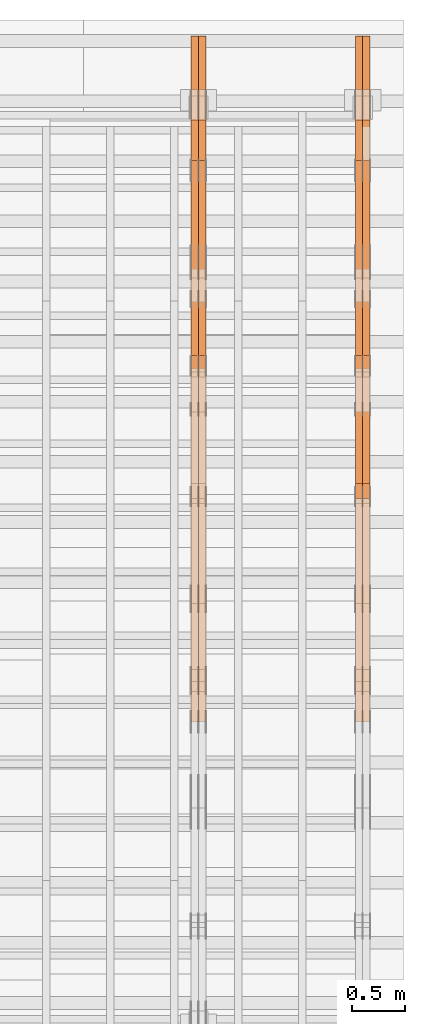
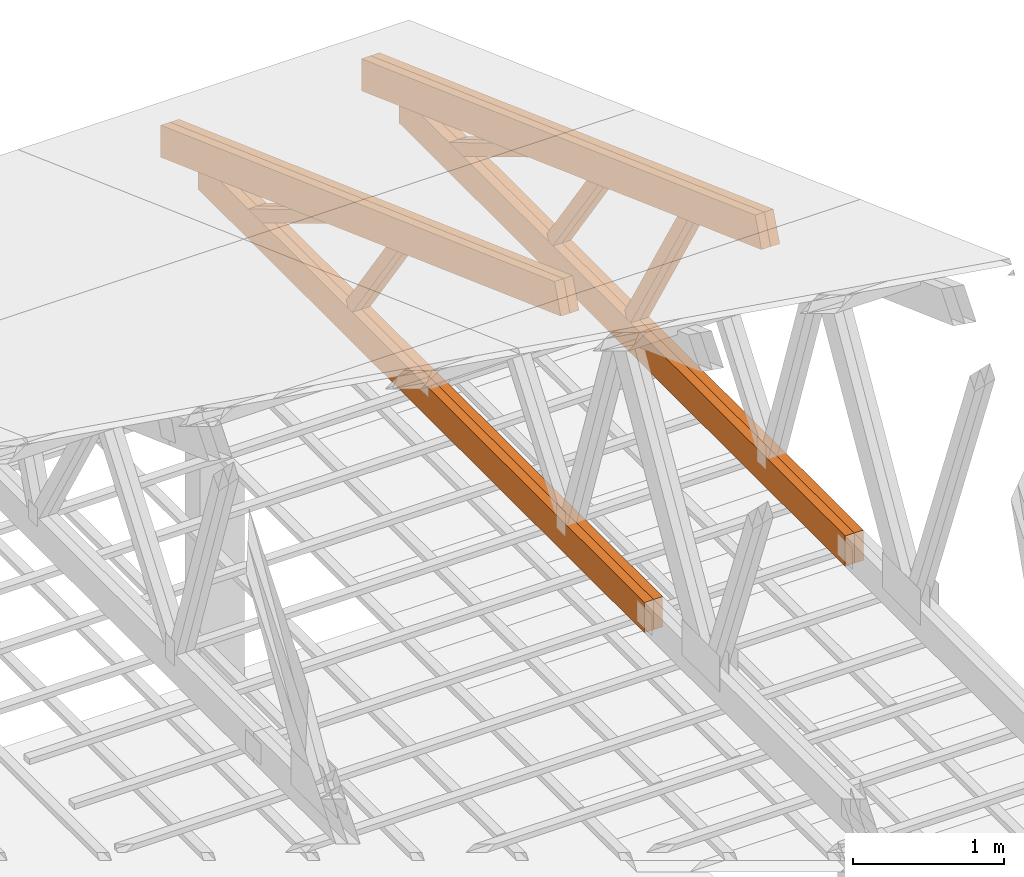
# One storey, part 66 of 189: 18 proxies.
"""IFC2X3 building model written with IfcOpenShell, lengths in millimetres."""

from ifc_helpers import new_model, entity, si_unit, converted_unit, derived_unit, direction, frame, origin, place, context, subcontext, project, spatial, polyline, outline, extrude, source, transform, mapped, material, type_object, type_shapes, element, save


model = new_model("IFC2X3")

# Units and contexts
model_context = context("Model", 3, precision=0.01, world=origin(), true_north=direction((6.12303176911189e-17, 1.0)))
body_context = subcontext(model_context, "Body", "Model", "MODEL_VIEW")
ifc_project = project(units=[si_unit("LENGTHUNIT", "METRE", prefix="MILLI"), si_unit("AREAUNIT", "SQUARE_METRE"), si_unit("VOLUMEUNIT", "CUBIC_METRE"), converted_unit("PLANEANGLEUNIT", "DEGREE", entity("IfcRatioMeasure", 0.0174532925199433), si_unit("PLANEANGLEUNIT", "RADIAN"), dimensions=[0, 0, 0, 0, 0, 0, 0]), si_unit("MASSUNIT", "GRAM", prefix="KILO"), derived_unit("MASSDENSITYUNIT", [(si_unit("MASSUNIT", "GRAM", prefix="KILO"), 1), (si_unit("LENGTHUNIT", "METRE"), -3)]), si_unit("TIMEUNIT", "SECOND"), si_unit("FREQUENCYUNIT", "HERTZ"), si_unit("THERMODYNAMICTEMPERATUREUNIT", "DEGREE_CELSIUS"), derived_unit("THERMALTRANSMITTANCEUNIT", [(si_unit("MASSUNIT", "GRAM", prefix="KILO"), 1), (si_unit("THERMODYNAMICTEMPERATUREUNIT", "KELVIN"), -1), (si_unit("TIMEUNIT", "SECOND"), -3)]), derived_unit("VOLUMETRICFLOWRATEUNIT", [(si_unit("LENGTHUNIT", "METRE"), 3), (si_unit("TIMEUNIT", "SECOND"), -1)]), si_unit("ELECTRICCURRENTUNIT", "AMPERE"), si_unit("ELECTRICVOLTAGEUNIT", "VOLT"), si_unit("POWERUNIT", "WATT"), si_unit("FORCEUNIT", "NEWTON"), si_unit("ILLUMINANCEUNIT", "LUX"), si_unit("LUMINOUSFLUXUNIT", "LUMEN"), si_unit("LUMINOUSINTENSITYUNIT", "CANDELA"), derived_unit("USERDEFINED", [(si_unit("MASSUNIT", "GRAM", prefix="KILO"), -1), (si_unit("LENGTHUNIT", "METRE"), -2), (si_unit("TIMEUNIT", "SECOND"), 3), (si_unit("LUMINOUSFLUXUNIT", "LUMEN"), 1)]), derived_unit("LINEARVELOCITYUNIT", [(si_unit("LENGTHUNIT", "METRE"), 1), (si_unit("TIMEUNIT", "SECOND"), -1)]), si_unit("PRESSUREUNIT", "PASCAL"), derived_unit("USERDEFINED", [(si_unit("LENGTHUNIT", "METRE"), -2), (si_unit("MASSUNIT", "GRAM", prefix="KILO"), 1), (si_unit("TIMEUNIT", "SECOND"), -2)])], contexts=[model_context])

# Site, building, storey
site_placement = place(None, origin())
site = spatial("IfcSite", under=ifc_project, at=site_placement, CompositionType="ELEMENT")
building_placement = place(site_placement, origin())
building = spatial("IfcBuilding", under=site, at=building_placement, CompositionType="ELEMENT")
storey_placement = place(building_placement, origin())
storey = spatial("IfcBuildingStorey", under=building, at=storey_placement, Name="Default", CompositionType="ELEMENT", Elevation=0.0)

# Proxies
ifc_material_1 = material(Name="IfcSurfaceStyle #271132")
building_element_proxy_type_1 = type_object("IfcBuildingElementProxyType", Name="T1-W11 271130", PredefinedType="NOTDEFINED", material=ifc_material_1)
shared_shape_1 = source(origin(), body_context, "Body", "SweptSolid", [
    extrude(outline(polyline([(-809.410890003667, -47.5000077306544), (561.624013869753, -47.5000077306544), (599.944137054867, -7.52294285037536e-05), (572.078784657538, 47.5000453453687), (-924.236045578491, 47.5000453453687), (-809.410890003667, -47.5000077306544)])), frame((599.944137054867, 47.5000453453687, 0.0), z_axis=(0.0, 0.0, 1.0), x_axis=(-1.0, 0.0, 0.0)), (0.0, 0.0, 1.0), 69.9999999999999),
])
type_shapes(building_element_proxy_type_1, [shared_shape_1])
proxy_1_placement = place(building_placement, frame((49840.0, 26434.7921369083, 220.965133687368), z_axis=(-1.0, 0.0, 0.0), x_axis=(0.0, -0.505995901100603, 0.862535882192381)))
element("IfcBuildingElementProxy", 1, at=proxy_1_placement, inside=storey, type_object=building_element_proxy_type_1, material=ifc_material_1, Name="T1-W11", context=body_context, shape_type="MappedRepresentation", body=[
    mapped(shared_shape_1, transform((0.0, 0.0, 0.0), scale=1.0)),
])
ifc_material_2 = material(Name="IfcSurfaceStyle #271066")
building_element_proxy_type_2 = type_object("IfcBuildingElementProxyType", Name="T1-W11 271064", PredefinedType="NOTDEFINED", material=ifc_material_2)
shared_shape_2 = source(origin(), body_context, "Body", "SweptSolid", [
    extrude(outline(polyline([(-809.410890003667, -47.5000077306544), (561.624013869753, -47.5000077306544), (599.944137054867, -7.52294285037536e-05), (572.078784657538, 47.5000453453687), (-924.236045578491, 47.5000453453687), (-809.410890003667, -47.5000077306544)])), frame((599.944137054867, 47.5000453453687, 0.0), z_axis=(0.0, 0.0, 1.0), x_axis=(-1.0, 0.0, 0.0)), (0.0, 0.0, 1.0), 69.9999999999999),
])
type_shapes(building_element_proxy_type_2, [shared_shape_2])
proxy_2_placement = place(building_placement, frame((49770.0, 26434.7921369083, 220.965133687368), z_axis=(-1.0, 0.0, 0.0), x_axis=(0.0, -0.505995901100603, 0.862535882192381)))
element("IfcBuildingElementProxy", 2, at=proxy_2_placement, inside=storey, type_object=building_element_proxy_type_2, material=ifc_material_2, Name="T1-W11", context=body_context, shape_type="MappedRepresentation", body=[
    mapped(shared_shape_2, transform((0.0, 0.0, 0.0), scale=1.0)),
])
ifc_material_3 = material(Name="IfcSurfaceStyle #270604")
building_element_proxy_type_3 = type_object("IfcBuildingElementProxyType", Name="T1-W13 270602", PredefinedType="NOTDEFINED", material=ifc_material_3)
shared_shape_3 = source(origin(), body_context, "Body", "SweptSolid", [
    extrude(outline(polyline([(-527.416466728212, -47.5000272833949), (387.658053197984, -47.5000272833949), (418.029495084182, -7.96824534414764e-06), (384.779443025059, 47.5000312675175), (-663.050524579013, 47.5000312675176), (-527.416466728212, -47.5000272833949)])), frame((418.029495084182, 47.5000671658844, 0.0), z_axis=(0.0, 0.0, 1.0), x_axis=(-1.0, 0.0, 0.0)), (0.0, 0.0, 1.0), 69.9999999999999),
])
type_shapes(building_element_proxy_type_3, [shared_shape_3])
proxy_3_placement = place(building_placement, frame((49840.0, 27471.0085508293, 217.760482033818), z_axis=(-1.0, 0.0, 0.0), x_axis=(0.0, -0.573462629043498, 0.819231721242848)))
element("IfcBuildingElementProxy", 3, at=proxy_3_placement, inside=storey, type_object=building_element_proxy_type_3, material=ifc_material_3, Name="T1-W13", context=body_context, shape_type="MappedRepresentation", body=[
    mapped(shared_shape_3, transform((0.0, 0.0, 0.0), scale=1.0)),
])
ifc_material_4 = material(Name="IfcSurfaceStyle #270538")
building_element_proxy_type_4 = type_object("IfcBuildingElementProxyType", Name="T1-W13 270536", PredefinedType="NOTDEFINED", material=ifc_material_4)
shared_shape_4 = source(origin(), body_context, "Body", "SweptSolid", [
    extrude(outline(polyline([(-527.416466728212, -47.5000272833949), (387.658053197984, -47.5000272833949), (418.029495084182, -7.96824534414764e-06), (384.779443025059, 47.5000312675175), (-663.050524579013, 47.5000312675176), (-527.416466728212, -47.5000272833949)])), frame((418.029495084182, 47.5000671658844, 0.0), z_axis=(0.0, 0.0, 1.0), x_axis=(-1.0, 0.0, 0.0)), (0.0, 0.0, 1.0), 69.9999999999999),
])
type_shapes(building_element_proxy_type_4, [shared_shape_4])
proxy_4_placement = place(building_placement, frame((49770.0, 27471.0085508293, 217.760482033818), z_axis=(-1.0, 0.0, 0.0), x_axis=(0.0, -0.573462629043498, 0.819231721242848)))
element("IfcBuildingElementProxy", 4, at=proxy_4_placement, inside=storey, type_object=building_element_proxy_type_4, material=ifc_material_4, Name="T1-W13", context=body_context, shape_type="MappedRepresentation", body=[
    mapped(shared_shape_4, transform((0.0, 0.0, 0.0), scale=1.0)),
])
ifc_material_5 = material(Name="IfcSurfaceStyle #270094")
building_element_proxy_type_5 = type_object("IfcBuildingElementProxyType", Name="T1-W12 270092", PredefinedType="NOTDEFINED", material=ifc_material_5)
shared_shape_5 = source(origin(), body_context, "Body", "SweptSolid", [
    extrude(outline(polyline([(-176.861423449428, -47.5000064161489), (503.856777435794, -47.5000064161489), (344.893496040196, 47.5000064161489), (-671.888850026563, 47.5000064161488), (-176.861423449428, -47.5000064161489)])), frame((503.856799890979, 47.5000428456028, 0.0), z_axis=(0.0, 0.0, 1.0), x_axis=(-1.0, 0.0, 0.0)), (0.0, 0.0, 1.0), 69.9999999999999),
])
type_shapes(building_element_proxy_type_5, [shared_shape_5])
proxy_5_placement = place(building_placement, frame((49840.0, 28785.6842742264, 163.452728724015), z_axis=(-1.0, 0.0, 0.0), x_axis=(0.0, -0.858392121304013, 0.51299411895576)))
element("IfcBuildingElementProxy", 5, at=proxy_5_placement, inside=storey, type_object=building_element_proxy_type_5, material=ifc_material_5, Name="T1-W12", context=body_context, shape_type="MappedRepresentation", body=[
    mapped(shared_shape_5, transform((0.0, 0.0, 0.0), scale=1.0)),
])
ifc_material_6 = material(Name="IfcSurfaceStyle #270037")
building_element_proxy_type_6 = type_object("IfcBuildingElementProxyType", Name="T1-W12 270035", PredefinedType="NOTDEFINED", material=ifc_material_6)
shared_shape_6 = source(origin(), body_context, "Body", "SweptSolid", [
    extrude(outline(polyline([(-176.861423449428, -47.5000064161489), (503.856777435794, -47.5000064161489), (344.893496040196, 47.5000064161489), (-671.888850026563, 47.5000064161488), (-176.861423449428, -47.5000064161489)])), frame((503.856799890979, 47.5000428456028, 0.0), z_axis=(0.0, 0.0, 1.0), x_axis=(-1.0, 0.0, 0.0)), (0.0, 0.0, 1.0), 69.9999999999999),
])
type_shapes(building_element_proxy_type_6, [shared_shape_6])
proxy_6_placement = place(building_placement, frame((49770.0, 28785.6842742264, 163.452728724015), z_axis=(-1.0, 0.0, 0.0), x_axis=(0.0, -0.858392121304013, 0.51299411895576)))
element("IfcBuildingElementProxy", 6, at=proxy_6_placement, inside=storey, type_object=building_element_proxy_type_6, material=ifc_material_6, Name="T1-W12", context=body_context, shape_type="MappedRepresentation", body=[
    mapped(shared_shape_6, transform((0.0, 0.0, 0.0), scale=1.0)),
])
ifc_material_7 = material(Name="IfcSurfaceStyle #269980")
building_element_proxy_type_7 = type_object("IfcBuildingElementProxyType", Name="T1-B1 269978", PredefinedType="NOTDEFINED", material=ifc_material_7)
shared_shape_7 = source(origin(), body_context, "Body", "SweptSolid", [
    extrude(outline(polyline([(-2430.09461669922, -125.855288696288), (3499.90538330078, -125.855288696288), (3499.90538330078, 119.144711303711), (-2139.62153320312, 119.144711303711), (-2430.09461669922, 13.4211547851552), (-2430.09461669922, -125.855288696288)])), frame((3499.90538330078, 119.144711303711, 0.0), z_axis=(0.0, 0.0, 1.0), x_axis=(-1.0, 0.0, 0.0)), (0.0, 0.0, 1.0), 69.9999999999996),
])
type_shapes(building_element_proxy_type_7, [shared_shape_7])
proxy_7_placement = place(building_placement, frame((49840.0, 23570.0, 245.0), z_axis=(-1.0, 0.0, 0.0), x_axis=(0.0, 1.0, 0.0)))
element("IfcBuildingElementProxy", 7, at=proxy_7_placement, inside=storey, type_object=building_element_proxy_type_7, material=ifc_material_7, Name="T1-B1", context=body_context, shape_type="MappedRepresentation", body=[
    mapped(shared_shape_7, transform((0.0, 0.0, 0.0), scale=1.0)),
])
ifc_material_8 = material(Name="IfcSurfaceStyle #269914")
building_element_proxy_type_8 = type_object("IfcBuildingElementProxyType", Name="T1-B1 269912", PredefinedType="NOTDEFINED", material=ifc_material_8)
shared_shape_8 = source(origin(), body_context, "Body", "SweptSolid", [
    extrude(outline(polyline([(-2430.09461669922, -125.855288696288), (3499.90538330078, -125.855288696288), (3499.90538330078, 119.144711303711), (-2139.62153320312, 119.144711303711), (-2430.09461669922, 13.4211547851552), (-2430.09461669922, -125.855288696288)])), frame((3499.90538330078, 119.144711303711, 0.0), z_axis=(0.0, 0.0, 1.0), x_axis=(-1.0, 0.0, 0.0)), (0.0, 0.0, 1.0), 69.9999999999996),
])
type_shapes(building_element_proxy_type_8, [shared_shape_8])
proxy_8_placement = place(building_placement, frame((49770.0, 23570.0, 245.0), z_axis=(-1.0, 0.0, 0.0), x_axis=(0.0, 1.0, 0.0)))
element("IfcBuildingElementProxy", 8, at=proxy_8_placement, inside=storey, type_object=building_element_proxy_type_8, material=ifc_material_8, Name="T1-B1", context=body_context, shape_type="MappedRepresentation", body=[
    mapped(shared_shape_8, transform((0.0, 0.0, 0.0), scale=1.0)),
])
ifc_material_9 = material(Name="IfcSurfaceStyle #268690")
building_element_proxy_type_9 = type_object("IfcBuildingElementProxyType", Name="T1-T2 268688", PredefinedType="NOTDEFINED", material=ifc_material_9)
shared_shape_9 = source(origin(), body_context, "Body", "SweptSolid", [
    extrude(outline(polyline([(-2807.70681121203, -122.500041939424), (2763.12044548192, -122.500041939424), (2852.29315104137, 122.500041939424), (-2807.70678531126, 122.500041939424), (-2807.70681121203, -122.500041939424)])), frame((2852.29315104137, 122.500041939424, 0.0), z_axis=(0.0, 0.0, 1.0), x_axis=(-1.0, 0.0, 0.0)), (0.0, 0.0, 1.0), 69.9999999999997),
])
type_shapes(building_element_proxy_type_9, [shared_shape_9])
proxy_9_placement = place(building_placement, frame((49840.0, 30000.0, -42.7086715698242), z_axis=(-1.0, 0.0, 0.0), x_axis=(0.0, -0.939692620785908, 0.342020143325669)))
element("IfcBuildingElementProxy", 9, at=proxy_9_placement, inside=storey, type_object=building_element_proxy_type_9, material=ifc_material_9, Name="T1-T2", context=body_context, shape_type="MappedRepresentation", body=[
    mapped(shared_shape_9, transform((0.0, 0.0, 0.0), scale=1.0)),
])
ifc_material_10 = material(Name="IfcSurfaceStyle #268633")
building_element_proxy_type_10 = type_object("IfcBuildingElementProxyType", Name="T1-T2 268631", PredefinedType="NOTDEFINED", material=ifc_material_10)
shared_shape_10 = source(origin(), body_context, "Body", "SweptSolid", [
    extrude(outline(polyline([(-2807.70681121203, -122.500041939424), (2763.12044548192, -122.500041939424), (2852.29315104137, 122.500041939424), (-2807.70678531126, 122.500041939424), (-2807.70681121203, -122.500041939424)])), frame((2852.29315104137, 122.500041939424, 0.0), z_axis=(0.0, 0.0, 1.0), x_axis=(-1.0, 0.0, 0.0)), (0.0, 0.0, 1.0), 69.9999999999997),
])
type_shapes(building_element_proxy_type_10, [shared_shape_10])
proxy_10_placement = place(building_placement, frame((49770.0, 30000.0, -42.7086715698242), z_axis=(-1.0, 0.0, 0.0), x_axis=(0.0, -0.939692620785908, 0.342020143325669)))
element("IfcBuildingElementProxy", 10, at=proxy_10_placement, inside=storey, type_object=building_element_proxy_type_10, material=ifc_material_10, Name="T1-T2", context=body_context, shape_type="MappedRepresentation", body=[
    mapped(shared_shape_10, transform((0.0, 0.0, 0.0), scale=1.0)),
])
ifc_material_11 = material(Name="IfcSurfaceStyle #254814")
building_element_proxy_type_11 = type_object("IfcBuildingElementProxyType", Name="T1-W13 254812", PredefinedType="NOTDEFINED", material=ifc_material_11)
shared_shape_11 = source(origin(), body_context, "Body", "SweptSolid", [
    extrude(outline(polyline([(-527.416466728212, -47.5000272833949), (387.658053197984, -47.5000272833949), (418.029495084182, -7.96824534414764e-06), (384.779443025059, 47.5000312675175), (-663.050524579013, 47.5000312675176), (-527.416466728212, -47.5000272833949)])), frame((418.029495084182, 47.5000671658844, 0.0), z_axis=(0.0, 0.0, 1.0), x_axis=(-1.0, 0.0, 0.0)), (0.0, 0.0, 1.0), 69.9999999999999),
])
type_shapes(building_element_proxy_type_11, [shared_shape_11])
proxy_11_placement = place(building_placement, frame((48300.0, 27471.0085508293, 217.760482033818), z_axis=(-1.0, 0.0, 0.0), x_axis=(0.0, -0.573462629043498, 0.819231721242848)))
element("IfcBuildingElementProxy", 11, at=proxy_11_placement, inside=storey, type_object=building_element_proxy_type_11, material=ifc_material_11, Name="T1-W13", context=body_context, shape_type="MappedRepresentation", body=[
    mapped(shared_shape_11, transform((0.0, 0.0, 0.0), scale=1.0)),
])
ifc_material_12 = material(Name="IfcSurfaceStyle #254748")
building_element_proxy_type_12 = type_object("IfcBuildingElementProxyType", Name="T1-W13 254746", PredefinedType="NOTDEFINED", material=ifc_material_12)
shared_shape_12 = source(origin(), body_context, "Body", "SweptSolid", [
    extrude(outline(polyline([(-527.416466728212, -47.5000272833949), (387.658053197984, -47.5000272833949), (418.029495084182, -7.96824534414764e-06), (384.779443025059, 47.5000312675175), (-663.050524579013, 47.5000312675176), (-527.416466728212, -47.5000272833949)])), frame((418.029495084182, 47.5000671658844, 0.0), z_axis=(0.0, 0.0, 1.0), x_axis=(-1.0, 0.0, 0.0)), (0.0, 0.0, 1.0), 69.9999999999999),
])
type_shapes(building_element_proxy_type_12, [shared_shape_12])
proxy_12_placement = place(building_placement, frame((48230.0, 27471.0085508293, 217.760482033818), z_axis=(-1.0, 0.0, 0.0), x_axis=(0.0, -0.573462629043498, 0.819231721242848)))
element("IfcBuildingElementProxy", 12, at=proxy_12_placement, inside=storey, type_object=building_element_proxy_type_12, material=ifc_material_12, Name="T1-W13", context=body_context, shape_type="MappedRepresentation", body=[
    mapped(shared_shape_12, transform((0.0, 0.0, 0.0), scale=1.0)),
])
ifc_material_13 = material(Name="IfcSurfaceStyle #254304")
building_element_proxy_type_13 = type_object("IfcBuildingElementProxyType", Name="T1-W12 254302", PredefinedType="NOTDEFINED", material=ifc_material_13)
shared_shape_13 = source(origin(), body_context, "Body", "SweptSolid", [
    extrude(outline(polyline([(-176.861423449428, -47.5000064161489), (503.856777435794, -47.5000064161489), (344.893496040196, 47.5000064161489), (-671.888850026563, 47.5000064161488), (-176.861423449428, -47.5000064161489)])), frame((503.856799890979, 47.5000428456028, 0.0), z_axis=(0.0, 0.0, 1.0), x_axis=(-1.0, 0.0, 0.0)), (0.0, 0.0, 1.0), 69.9999999999999),
])
type_shapes(building_element_proxy_type_13, [shared_shape_13])
proxy_13_placement = place(building_placement, frame((48300.0, 28785.6842742264, 163.452728724015), z_axis=(-1.0, 0.0, 0.0), x_axis=(0.0, -0.858392121304013, 0.51299411895576)))
element("IfcBuildingElementProxy", 13, at=proxy_13_placement, inside=storey, type_object=building_element_proxy_type_13, material=ifc_material_13, Name="T1-W12", context=body_context, shape_type="MappedRepresentation", body=[
    mapped(shared_shape_13, transform((0.0, 0.0, 0.0), scale=1.0)),
])
ifc_material_14 = material(Name="IfcSurfaceStyle #254247")
building_element_proxy_type_14 = type_object("IfcBuildingElementProxyType", Name="T1-W12 254245", PredefinedType="NOTDEFINED", material=ifc_material_14)
shared_shape_14 = source(origin(), body_context, "Body", "SweptSolid", [
    extrude(outline(polyline([(-176.861423449428, -47.5000064161489), (503.856777435794, -47.5000064161489), (344.893496040196, 47.5000064161489), (-671.888850026563, 47.5000064161488), (-176.861423449428, -47.5000064161489)])), frame((503.856799890979, 47.5000428456028, 0.0), z_axis=(0.0, 0.0, 1.0), x_axis=(-1.0, 0.0, 0.0)), (0.0, 0.0, 1.0), 69.9999999999999),
])
type_shapes(building_element_proxy_type_14, [shared_shape_14])
proxy_14_placement = place(building_placement, frame((48230.0, 28785.6842742264, 163.452728724015), z_axis=(-1.0, 0.0, 0.0), x_axis=(0.0, -0.858392121304013, 0.51299411895576)))
element("IfcBuildingElementProxy", 14, at=proxy_14_placement, inside=storey, type_object=building_element_proxy_type_14, material=ifc_material_14, Name="T1-W12", context=body_context, shape_type="MappedRepresentation", body=[
    mapped(shared_shape_14, transform((0.0, 0.0, 0.0), scale=1.0)),
])
ifc_material_15 = material(Name="IfcSurfaceStyle #254190")
building_element_proxy_type_15 = type_object("IfcBuildingElementProxyType", Name="T1-B1 254188", PredefinedType="NOTDEFINED", material=ifc_material_15)
shared_shape_15 = source(origin(), body_context, "Body", "SweptSolid", [
    extrude(outline(polyline([(-2430.09461669922, -125.855288696288), (3499.90538330078, -125.855288696288), (3499.90538330078, 119.144711303711), (-2139.62153320312, 119.144711303711), (-2430.09461669922, 13.4211547851552), (-2430.09461669922, -125.855288696288)])), frame((3499.90538330078, 119.144711303711, 0.0), z_axis=(0.0, 0.0, 1.0), x_axis=(-1.0, 0.0, 0.0)), (0.0, 0.0, 1.0), 69.9999999999996),
])
type_shapes(building_element_proxy_type_15, [shared_shape_15])
proxy_15_placement = place(building_placement, frame((48300.0, 23570.0, 245.0), z_axis=(-1.0, 0.0, 0.0), x_axis=(0.0, 1.0, 0.0)))
element("IfcBuildingElementProxy", 15, at=proxy_15_placement, inside=storey, type_object=building_element_proxy_type_15, material=ifc_material_15, Name="T1-B1", context=body_context, shape_type="MappedRepresentation", body=[
    mapped(shared_shape_15, transform((0.0, 0.0, 0.0), scale=1.0)),
])
ifc_material_16 = material(Name="IfcSurfaceStyle #254124")
building_element_proxy_type_16 = type_object("IfcBuildingElementProxyType", Name="T1-B1 254122", PredefinedType="NOTDEFINED", material=ifc_material_16)
shared_shape_16 = source(origin(), body_context, "Body", "SweptSolid", [
    extrude(outline(polyline([(-2430.09461669922, -125.855288696288), (3499.90538330078, -125.855288696288), (3499.90538330078, 119.144711303711), (-2139.62153320312, 119.144711303711), (-2430.09461669922, 13.4211547851552), (-2430.09461669922, -125.855288696288)])), frame((3499.90538330078, 119.144711303711, 0.0), z_axis=(0.0, 0.0, 1.0), x_axis=(-1.0, 0.0, 0.0)), (0.0, 0.0, 1.0), 69.9999999999996),
])
type_shapes(building_element_proxy_type_16, [shared_shape_16])
proxy_16_placement = place(building_placement, frame((48230.0, 23570.0, 245.0), z_axis=(-1.0, 0.0, 0.0), x_axis=(0.0, 1.0, 0.0)))
element("IfcBuildingElementProxy", 16, at=proxy_16_placement, inside=storey, type_object=building_element_proxy_type_16, material=ifc_material_16, Name="T1-B1", context=body_context, shape_type="MappedRepresentation", body=[
    mapped(shared_shape_16, transform((0.0, 0.0, 0.0), scale=1.0)),
])
ifc_material_17 = material(Name="IfcSurfaceStyle #252900")
building_element_proxy_type_17 = type_object("IfcBuildingElementProxyType", Name="T1-T2 252898", PredefinedType="NOTDEFINED", material=ifc_material_17)
shared_shape_17 = source(origin(), body_context, "Body", "SweptSolid", [
    extrude(outline(polyline([(-2807.70681121203, -122.500041939424), (2763.12044548192, -122.500041939424), (2852.29315104137, 122.500041939424), (-2807.70678531126, 122.500041939424), (-2807.70681121203, -122.500041939424)])), frame((2852.29315104137, 122.500041939424, 0.0), z_axis=(0.0, 0.0, 1.0), x_axis=(-1.0, 0.0, 0.0)), (0.0, 0.0, 1.0), 69.9999999999997),
])
type_shapes(building_element_proxy_type_17, [shared_shape_17])
proxy_17_placement = place(building_placement, frame((48300.0, 30000.0, -42.7086715698242), z_axis=(-1.0, 0.0, 0.0), x_axis=(0.0, -0.939692620785908, 0.342020143325669)))
element("IfcBuildingElementProxy", 17, at=proxy_17_placement, inside=storey, type_object=building_element_proxy_type_17, material=ifc_material_17, Name="T1-T2", context=body_context, shape_type="MappedRepresentation", body=[
    mapped(shared_shape_17, transform((0.0, 0.0, 0.0), scale=1.0)),
])
ifc_material_18 = material(Name="IfcSurfaceStyle #252843")
building_element_proxy_type_18 = type_object("IfcBuildingElementProxyType", Name="T1-T2 252841", PredefinedType="NOTDEFINED", material=ifc_material_18)
shared_shape_18 = source(origin(), body_context, "Body", "SweptSolid", [
    extrude(outline(polyline([(-2807.70681121203, -122.500041939424), (2763.12044548192, -122.500041939424), (2852.29315104137, 122.500041939424), (-2807.70678531126, 122.500041939424), (-2807.70681121203, -122.500041939424)])), frame((2852.29315104137, 122.500041939424, 0.0), z_axis=(0.0, 0.0, 1.0), x_axis=(-1.0, 0.0, 0.0)), (0.0, 0.0, 1.0), 69.9999999999997),
])
type_shapes(building_element_proxy_type_18, [shared_shape_18])
proxy_18_placement = place(building_placement, frame((48230.0, 30000.0, -42.7086715698242), z_axis=(-1.0, 0.0, 0.0), x_axis=(0.0, -0.939692620785908, 0.342020143325669)))
element("IfcBuildingElementProxy", 18, at=proxy_18_placement, inside=storey, type_object=building_element_proxy_type_18, material=ifc_material_18, Name="T1-T2", context=body_context, shape_type="MappedRepresentation", body=[
    mapped(shared_shape_18, transform((0.0, 0.0, 0.0), scale=1.0)),
])

save(model, "model.ifc")
